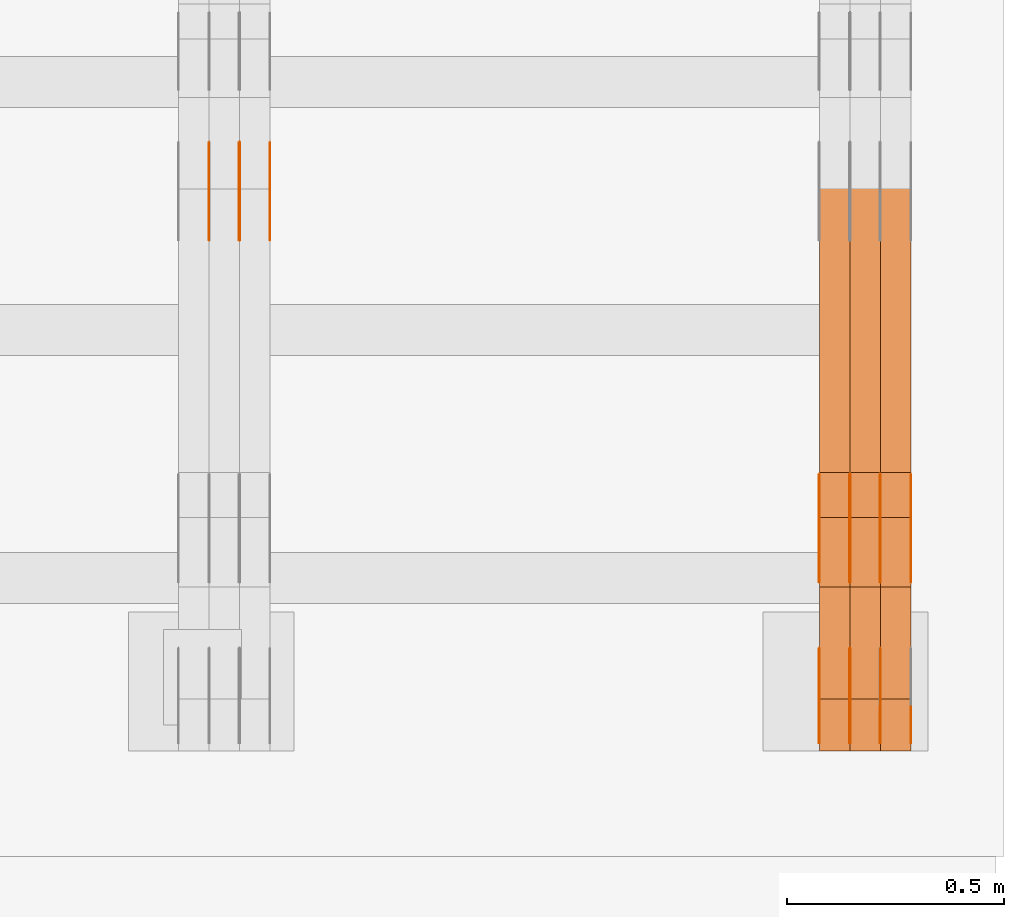
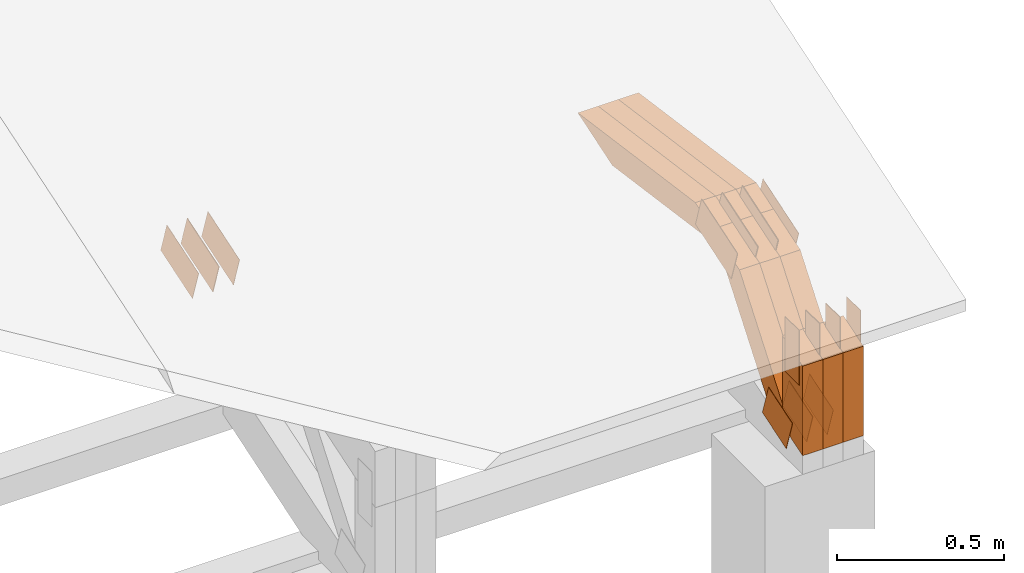
# One storey, part 307 of 385: 29 proxies.
"""IFC2X3 building model written with IfcOpenShell, lengths in millimetres."""

import ifcopenshell
import ifcopenshell.guid

model = None  # the IFC model being written
_history = None  # IfcOwnerHistory: only IFC2X3 demands one
_inside = {}  # id of a spatial element -> (the spatial element, [elements in it])
_under = {}  # id of a project, library or spatial element -> (it, [spatial elements below it])
_declared = {}  # id of a project -> (the project, [libraries it declares])
_typed = {}  # id of a type object -> (the type object, [elements of that type])
_made_of = {}  # id of a material, layer set ... -> (it, [elements and type objects made of it])


def new_model(schema):
    """Start an empty IFC model of exactly this schema.

    Asked for "IFC4X3", IfcOpenShell would pick the latest addendum, in which some entities
    have other attributes; the version numbers below select the first issue.
    IFC2X3 requires an IfcOwnerHistory on every rooted entity: one is made here for all.
    """
    global model, _history
    if schema == "IFC4X3":
        model = ifcopenshell.file(schema_version=(4, 3, 0, 0))
    else:
        model = ifcopenshell.file(schema=schema)
    _inside.clear()
    _under.clear()
    _declared.clear()
    _typed.clear()
    _made_of.clear()
    _history = None
    if model.schema == "IFC2X3":
        org = make("IfcOrganization", Name="unknown")
        user = make(
            "IfcPersonAndOrganization",
            ThePerson=make("IfcPerson", FamilyName="unknown"),
            TheOrganization=org,
        )
        app = make(
            "IfcApplication",
            ApplicationDeveloper=org,
            Version="unknown",
            ApplicationFullName="unknown",
            ApplicationIdentifier="unknown",
        )
        _history = make(
            "IfcOwnerHistory",
            OwningUser=user,
            OwningApplication=app,
            ChangeAction="ADDED",
            CreationDate=0,
        )
    return model


def make(cls, **values):
    """One entity of the class cls with the attributes given. An attribute that is None is left unset."""
    return model.create_entity(
        cls, **{name: value for name, value in values.items() if value is not None}
    )


def entity(cls, *values):
    """Any entity or typed value of the class cls, its attributes in the order of the schema. None: left unset."""
    e = model.create_entity(cls)
    for i, value in enumerate(values):
        if value is not None:
            e[i] = value
    return e


def rooted(cls, **values):
    """An entity with a GlobalId (a new one), such as an element, a storey or a relation."""
    return make(cls, GlobalId=ifcopenshell.guid.new(), OwnerHistory=_history, **values)


def si_unit(unit_type, name, prefix=None):
    """IfcSIUnit, for example si_unit("LENGTHUNIT", "METRE", prefix="MILLI")."""
    return make("IfcSIUnit", UnitType=unit_type, Prefix=prefix, Name=name)


def converted_unit(unit_type, name, factor, base, dimensions=None, offset=None):
    """IfcConversionBasedUnit, such as the inch: factor (a typed value) times the base unit."""
    return make(
        "IfcConversionBasedUnit"
        if offset is None
        else "IfcConversionBasedUnitWithOffset",
        ConversionOffset=offset,
        Dimensions=None
        if dimensions is None
        else entity("IfcDimensionalExponents", *dimensions),
        UnitType=unit_type,
        Name=name,
        ConversionFactor=make(
            "IfcMeasureWithUnit", ValueComponent=factor, UnitComponent=base
        ),
    )


def derived_unit(unit_type, elements):
    """IfcDerivedUnit: a product of units, each with its exponent."""
    return make(
        "IfcDerivedUnit",
        Elements=[
            make("IfcDerivedUnitElement", Unit=unit, Exponent=power)
            for unit, power in elements
        ],
        UnitType=unit_type,
    )


def assignment(units):
    """IfcUnitAssignment: the units of a project."""
    return None if units is None else make("IfcUnitAssignment", Units=units)


def point(xyz):
    """IfcCartesianPoint."""
    return None if xyz is None else make("IfcCartesianPoint", Coordinates=xyz)


def direction(xyz):
    """IfcDirection."""
    return None if xyz is None else make("IfcDirection", DirectionRatios=xyz)


def frame(location, z_axis=None, x_axis=None):
    """IfcAxis2Placement3D, a coordinate frame: its origin and axes. An axis left out is left unset."""
    return make(
        "IfcAxis2Placement3D",
        Location=point(location),
        Axis=direction(z_axis),
        RefDirection=direction(x_axis),
    )


def frame_2d(location, x_axis=None):
    """IfcAxis2Placement2D, a coordinate frame in the plane: its origin and x axis."""
    return make(
        "IfcAxis2Placement2D", Location=point(location), RefDirection=direction(x_axis)
    )


def origin():
    """The frame at (0, 0, 0) with its axes left unset."""
    return frame((0.0, 0.0, 0.0))


def place(relative_to, where):
    """IfcLocalPlacement: puts the frame where relative to a parent placement (None: the world)."""
    return make(
        "IfcLocalPlacement", PlacementRelTo=relative_to, RelativePlacement=where
    )


def context(
    kind, dimensions, precision=None, world=None, true_north=None, identifier=None
):
    """IfcGeometricRepresentationContext, for example the 3D "Model" context."""
    return make(
        "IfcGeometricRepresentationContext",
        ContextIdentifier=identifier,
        ContextType=kind,
        CoordinateSpaceDimension=dimensions,
        Precision=precision,
        WorldCoordinateSystem=world,
        TrueNorth=true_north,
    )


def subcontext(parent, identifier, kind, view, scale=None):
    """IfcGeometricRepresentationSubContext, for example "Body" below "Model"."""
    return make(
        "IfcGeometricRepresentationSubContext",
        ContextIdentifier=identifier,
        ContextType=kind,
        ParentContext=parent,
        TargetScale=scale,
        TargetView=view,
    )


def project(units=None, contexts=None):
    """IfcProject with its units and contexts."""
    return rooted(
        "IfcProject",
        Name="project",
        RepresentationContexts=contexts,
        UnitsInContext=assignment(units),
    )


def spatial(cls, under=None, at=None, **own):
    """A site, building, storey or space (cls), placed at a placement, below another one or the project."""
    s = rooted(cls, ObjectPlacement=at, **own)
    if under is not None:
        _under.setdefault(under.id(), (under, []))[1].append(s)
    return s


def polyline(points):
    """IfcPolyline through the points."""
    return make("IfcPolyline", Points=[point(p) for p in points])


def profile(cls, at=None, kind="AREA", **sizes):
    """A parametric profile (cls). Its sizes go by their IFC names, for example OverallWidth=200.0."""
    return make(cls, ProfileType=kind, Position=at, **sizes)


def rectangle(**sizes):
    """IfcRectangleProfileDef."""
    return profile("IfcRectangleProfileDef", **sizes)


def outline(outer, holes=None, kind="AREA"):
    """IfcArbitraryClosedProfileDef: a profile drawn as a closed curve; with holes, ...WithVoids."""
    if holes is None:
        return make("IfcArbitraryClosedProfileDef", ProfileType=kind, OuterCurve=outer)
    return make(
        "IfcArbitraryProfileDefWithVoids",
        ProfileType=kind,
        OuterCurve=outer,
        InnerCurves=holes,
    )


def extrude(swept, where, along, depth):
    """IfcExtrudedAreaSolid: the profile swept, set in the frame where, extruded along a direction by depth."""
    return make(
        "IfcExtrudedAreaSolid",
        SweptArea=swept,
        Position=where,
        ExtrudedDirection=direction(along),
        Depth=depth,
    )


def shape(context_of_items, identifier, shape_type, items):
    """IfcShapeRepresentation: the items that make up one representation, for example the "Body"."""
    return make(
        "IfcShapeRepresentation",
        ContextOfItems=context_of_items,
        RepresentationIdentifier=identifier,
        RepresentationType=shape_type,
        Items=items,
    )


def source(mapping_origin, context_of_items, identifier, shape_type, items):
    """IfcRepresentationMap: a shape defined once, which mapped items show again and again."""
    return make(
        "IfcRepresentationMap",
        MappingOrigin=mapping_origin,
        MappedRepresentation=shape(context_of_items, identifier, shape_type, items),
    )


def transform(
    local_origin,
    x_axis=None,
    y_axis=None,
    z_axis=None,
    scale=None,
    scale2=None,
    scale3=None,
    uniform=True,
):
    """IfcCartesianTransformationOperator3D, or its non-uniform kind. x_axis, y_axis, z_axis: its Axis1, 2, 3."""
    if uniform:
        return make(
            "IfcCartesianTransformationOperator3D",
            Axis1=direction(x_axis),
            Axis2=direction(y_axis),
            LocalOrigin=point(local_origin),
            Scale=scale,
            Axis3=direction(z_axis),
        )
    return make(
        "IfcCartesianTransformationOperator3DnonUniform",
        Axis1=direction(x_axis),
        Axis2=direction(y_axis),
        LocalOrigin=point(local_origin),
        Scale=scale,
        Axis3=direction(z_axis),
        Scale2=scale2,
        Scale3=scale3,
    )


def mapped(mapping_source, mapping_target):
    """IfcMappedItem: shows the shape of a source again, moved by a transform."""
    return make(
        "IfcMappedItem", MappingSource=mapping_source, MappingTarget=mapping_target
    )


def material(Name=None, Category=None):
    """IfcMaterial."""
    return make("IfcMaterial", Name=Name, Category=Category)


def made_of(thing, what):
    """Note that an element or type object is made of a material, layer set ...; save() writes the relation."""
    if what is not None:
        _made_of.setdefault(what.id(), (what, []))[1].append(thing)
    return thing


def type_object(cls, material=None, **own):
    """A type object (cls), such as IfcWallType, which elements share."""
    return made_of(rooted(cls, **own), material)


def type_shapes(of_type, sources):
    """Give a type object the sources (RepresentationMaps) that its elements show as mapped items."""
    of_type.RepresentationMaps = sources


def element(
    cls,
    number,
    at=None,
    inside=None,
    cuts=None,
    type_object=None,
    material=None,
    context=None,
    identifier="Body",
    shape_type=None,
    held_by="IfcProductDefinitionShape",
    body=None,
    shapes=None,
    **own,
):
    """One element of the class cls, such as IfcWall. Its Tag is "e" and its number.

    at: its placement. inside: the storey or other place that contains it. cuts: it is an
    opening in that element (IfcRelVoidsElement). A single representation is given by context,
    identifier, shape_type and body (its items); several are given by shapes. held_by: the class
    of the entity that holds the representations. save() writes the other relations.
    """
    e = rooted(cls, Tag="e%d" % number, ObjectPlacement=at, **own)
    if body is not None:
        shapes = [shape(context, identifier, shape_type, body)]
    if shapes is not None:
        e.Representation = make(held_by, Representations=shapes)
    if inside is not None:
        _inside.setdefault(inside.id(), (inside, []))[1].append(e)
    if cuts is not None:
        rooted(
            "IfcRelVoidsElement", RelatingBuildingElement=cuts, RelatedOpeningElement=e
        )
    if type_object is not None:
        _typed.setdefault(type_object.id(), (type_object, []))[1].append(e)
    return made_of(e, material)


def aggregate(whole, parts):
    """IfcRelAggregates: a whole, such as a stair, and the parts it consists of."""
    return rooted("IfcRelAggregates", RelatingObject=whole, RelatedObjects=parts)


def save(model, path):
    """Write the relations noted so far, then the file.

    IfcRelAggregates (storeys below a building ...), IfcRelContainedInSpatialStructure (elements
    in a storey), IfcRelDefinesByType, IfcRelAssociatesMaterial and IfcRelDeclares: one each for
    every whole, place, type object, material and project.
    """
    for whole, parts in _under.values():
        aggregate(whole, parts)
    for where, things in _inside.values():
        rooted(
            "IfcRelContainedInSpatialStructure",
            RelatedElements=things,
            RelatingStructure=where,
        )
    for kind, things in _typed.values():
        rooted("IfcRelDefinesByType", RelatedObjects=things, RelatingType=kind)
    for what, things in _made_of.values():
        rooted("IfcRelAssociatesMaterial", RelatedObjects=things, RelatingMaterial=what)
    for by, libraries in _declared.values():
        rooted("IfcRelDeclares", RelatingContext=by, RelatedDefinitions=libraries)
    model.write(path)


model = new_model("IFC2X3")

# Units and contexts
model_context = context("Model", 3, precision=0.01, world=origin(), true_north=direction((6.12303176911189e-17, 1.0)))
body_context = subcontext(model_context, "Body", "Model", "MODEL_VIEW")
ifc_project = project(units=[si_unit("LENGTHUNIT", "METRE", prefix="MILLI"), si_unit("AREAUNIT", "SQUARE_METRE"), si_unit("VOLUMEUNIT", "CUBIC_METRE"), converted_unit("PLANEANGLEUNIT", "DEGREE", entity("IfcRatioMeasure", 0.0174532925199433), si_unit("PLANEANGLEUNIT", "RADIAN"), dimensions=[0, 0, 0, 0, 0, 0, 0]), si_unit("MASSUNIT", "GRAM", prefix="KILO"), derived_unit("MASSDENSITYUNIT", [(si_unit("MASSUNIT", "GRAM", prefix="KILO"), 1), (si_unit("LENGTHUNIT", "METRE"), -3)]), si_unit("TIMEUNIT", "SECOND"), si_unit("FREQUENCYUNIT", "HERTZ"), si_unit("THERMODYNAMICTEMPERATUREUNIT", "DEGREE_CELSIUS"), derived_unit("THERMALTRANSMITTANCEUNIT", [(si_unit("MASSUNIT", "GRAM", prefix="KILO"), 1), (si_unit("THERMODYNAMICTEMPERATUREUNIT", "KELVIN"), -1), (si_unit("TIMEUNIT", "SECOND"), -3)]), derived_unit("VOLUMETRICFLOWRATEUNIT", [(si_unit("LENGTHUNIT", "METRE"), 3), (si_unit("TIMEUNIT", "SECOND"), -1)]), si_unit("ELECTRICCURRENTUNIT", "AMPERE"), si_unit("ELECTRICVOLTAGEUNIT", "VOLT"), si_unit("POWERUNIT", "WATT"), si_unit("FORCEUNIT", "NEWTON", prefix="KILO"), si_unit("ILLUMINANCEUNIT", "LUX"), si_unit("LUMINOUSFLUXUNIT", "LUMEN"), si_unit("LUMINOUSINTENSITYUNIT", "CANDELA"), derived_unit("USERDEFINED", [(si_unit("MASSUNIT", "GRAM", prefix="KILO"), -1), (si_unit("LENGTHUNIT", "METRE"), -2), (si_unit("TIMEUNIT", "SECOND"), 3), (si_unit("LUMINOUSFLUXUNIT", "LUMEN"), 1)]), derived_unit("LINEARVELOCITYUNIT", [(si_unit("LENGTHUNIT", "METRE"), 1), (si_unit("TIMEUNIT", "SECOND"), -1)]), si_unit("PRESSUREUNIT", "PASCAL"), derived_unit("USERDEFINED", [(si_unit("LENGTHUNIT", "METRE"), -2), (si_unit("MASSUNIT", "GRAM", prefix="KILO"), 1), (si_unit("TIMEUNIT", "SECOND"), -2)])], contexts=[model_context])

# Site, building, storey
site_placement = place(None, origin())
site = spatial("IfcSite", under=ifc_project, at=site_placement, CompositionType="ELEMENT")
building_placement = place(site_placement, origin())
building = spatial("IfcBuilding", under=site, at=building_placement, CompositionType="ELEMENT")
storey_placement = place(building_placement, origin())
storey = spatial("IfcBuildingStorey", under=building, at=storey_placement, Name="Default", CompositionType="ELEMENT", Elevation=0.0)

# Proxies
ifc_material_1 = material(Name="IfcSurfaceStyle #615370")
building_element_proxy_type_1 = type_object("IfcBuildingElementProxyType", PredefinedType="NOTDEFINED", material=ifc_material_1)
shared_shape_1 = source(origin(), body_context, "Body", "SweptSolid", [
    extrude(outline(polyline([(-74.999865408764, -60.0000379172698), (74.9998729365771, -60.0000379172698), (74.9998642299588, 60.0000379172698), (-74.9998717577719, 60.0000379172698), (-74.999865408764, -60.0000379172698)])), frame((75.0005044383734, 60.0001679035349, 0.0), z_axis=(0.0, 0.0, 1.0), x_axis=(-1.0, 0.0, 0.0)), (0.0, 0.0, 1.0), 1.3),
])
type_shapes(building_element_proxy_type_1, [shared_shape_1])
proxy_1_placement = place(building_placement, frame((49791.3, 2998.66143710397, 150.423871180894), z_axis=(-1.0, 0.0, 0.0), x_axis=(0.0, 0.951056516295124, 0.309016994375039)))
element("IfcBuildingElementProxy", 1, at=proxy_1_placement, inside=storey, type_object=building_element_proxy_type_1, material=ifc_material_1, context=body_context, shape_type="MappedRepresentation", body=[
    mapped(shared_shape_1, transform((0.0, 0.0, 0.0), scale=1.0)),
])
ifc_material_2 = material(Name="IfcSurfaceStyle #615313")
building_element_proxy_type_2 = type_object("IfcBuildingElementProxyType", PredefinedType="NOTDEFINED", material=ifc_material_2)
shared_shape_2 = source(origin(), body_context, "Body", "SweptSolid", [
    extrude(outline(polyline([(-74.999865408764, -60.0000379172698), (74.9998729365771, -60.0000379172698), (74.9998642299588, 60.0000379172698), (-74.9998717577719, 60.0000379172698), (-74.999865408764, -60.0000379172698)])), frame((75.0005044383734, 60.0001679035349, 0.0), z_axis=(0.0, 0.0, 1.0), x_axis=(-1.0, 0.0, 0.0)), (0.0, 0.0, 1.0), 1.29999999999999),
])
type_shapes(building_element_proxy_type_2, [shared_shape_2])
proxy_2_placement = place(building_placement, frame((49720.0, 2998.66143710397, 150.423871180894), z_axis=(-1.0, 0.0, 0.0), x_axis=(0.0, 0.951056516295124, 0.309016994375039)))
element("IfcBuildingElementProxy", 2, at=proxy_2_placement, inside=storey, type_object=building_element_proxy_type_2, material=ifc_material_2, context=body_context, shape_type="MappedRepresentation", body=[
    mapped(shared_shape_2, transform((0.0, 0.0, 0.0), scale=1.0)),
])
ifc_material_3 = material(Name="IfcSurfaceStyle #615256")
building_element_proxy_type_3 = type_object("IfcBuildingElementProxyType", PredefinedType="NOTDEFINED", material=ifc_material_3)
shared_shape_3 = source(origin(), body_context, "Body", "SweptSolid", [
    extrude(outline(polyline([(-74.999865408764, -60.0000379172698), (74.9998729365771, -60.0000379172698), (74.9998642299588, 60.0000379172698), (-74.9998717577719, 60.0000379172698), (-74.999865408764, -60.0000379172698)])), frame((75.0005044383734, 60.0001679035349, 0.0), z_axis=(0.0, 0.0, 1.0), x_axis=(-1.0, 0.0, 0.0)), (0.0, 0.0, 1.0), 1.29999999999999),
])
type_shapes(building_element_proxy_type_3, [shared_shape_3])
proxy_3_placement = place(building_placement, frame((49721.3, 2998.66143710397, 150.423871180894), z_axis=(-1.0, 0.0, 0.0), x_axis=(0.0, 0.951056516295124, 0.309016994375039)))
element("IfcBuildingElementProxy", 3, at=proxy_3_placement, inside=storey, type_object=building_element_proxy_type_3, material=ifc_material_3, context=body_context, shape_type="MappedRepresentation", body=[
    mapped(shared_shape_3, transform((0.0, 0.0, 0.0), scale=1.0)),
])
ifc_material_4 = material(Name="IfcSurfaceStyle #615199")
building_element_proxy_type_4 = type_object("IfcBuildingElementProxyType", PredefinedType="NOTDEFINED", material=ifc_material_4)
shared_shape_4 = source(origin(), body_context, "Body", "SweptSolid", [
    extrude(outline(polyline([(-74.999865408764, -60.0000379172698), (74.9998729365771, -60.0000379172698), (74.9998642299588, 60.0000379172698), (-74.9998717577719, 60.0000379172698), (-74.999865408764, -60.0000379172698)])), frame((75.0005044383734, 60.0001679035349, 0.0), z_axis=(0.0, 0.0, 1.0), x_axis=(-1.0, 0.0, 0.0)), (0.0, 0.0, 1.0), 1.29999999999999),
])
type_shapes(building_element_proxy_type_4, [shared_shape_4])
proxy_4_placement = place(building_placement, frame((49650.0, 2998.66143710397, 150.423871180894), z_axis=(-1.0, 0.0, 0.0), x_axis=(0.0, 0.951056516295124, 0.309016994375039)))
element("IfcBuildingElementProxy", 4, at=proxy_4_placement, inside=storey, type_object=building_element_proxy_type_4, material=ifc_material_4, context=body_context, shape_type="MappedRepresentation", body=[
    mapped(shared_shape_4, transform((0.0, 0.0, 0.0), scale=1.0)),
])
ifc_material_5 = material(Name="IfcSurfaceStyle #606934")
building_element_proxy_type_5 = type_object("IfcBuildingElementProxyType", PredefinedType="NOTDEFINED", material=ifc_material_5)
shared_shape_5 = source(origin(), body_context, "Body", "SweptSolid", [
    extrude(outline(polyline([(-112.500266735783, -59.9999130784581), (112.500275442392, -59.9999130784581), (112.500262020557, 59.9999130784582), (-112.500270727166, 59.9999130784581), (-112.500266735783, -59.9999130784581)])), frame((112.500275442392, 60.0001020984692, 0.0), z_axis=(0.0, 0.0, 1.0), x_axis=(-1.0, 0.0, 0.0)), (0.0, 0.0, 1.0), 1.3),
])
type_shapes(building_element_proxy_type_5, [shared_shape_5])
proxy_5_placement = place(building_placement, frame((49861.3, 3327.32420598508, 571.284602786019), z_axis=(-1.0, 0.0, 0.0), x_axis=(0.0, 0.951056516295154, 0.309016994374948)))
element("IfcBuildingElementProxy", 5, at=proxy_5_placement, inside=storey, type_object=building_element_proxy_type_5, material=ifc_material_5, context=body_context, shape_type="MappedRepresentation", body=[
    mapped(shared_shape_5, transform((0.0, 0.0, 0.0), scale=1.0)),
])
ifc_material_6 = material(Name="IfcSurfaceStyle #606877")
building_element_proxy_type_6 = type_object("IfcBuildingElementProxyType", PredefinedType="NOTDEFINED", material=ifc_material_6)
shared_shape_6 = source(origin(), body_context, "Body", "SweptSolid", [
    extrude(outline(polyline([(-112.500266735783, -59.9999130784581), (112.500275442392, -59.9999130784581), (112.500262020557, 59.9999130784582), (-112.500270727166, 59.9999130784581), (-112.500266735783, -59.9999130784581)])), frame((112.500275442392, 60.0001020984692, 0.0), z_axis=(0.0, 0.0, 1.0), x_axis=(-1.0, 0.0, 0.0)), (0.0, 0.0, 1.0), 1.3),
])
type_shapes(building_element_proxy_type_6, [shared_shape_6])
proxy_6_placement = place(building_placement, frame((49790.0, 3327.32420598508, 571.284602786019), z_axis=(-1.0, 0.0, 0.0), x_axis=(0.0, 0.951056516295154, 0.309016994374948)))
element("IfcBuildingElementProxy", 6, at=proxy_6_placement, inside=storey, type_object=building_element_proxy_type_6, material=ifc_material_6, context=body_context, shape_type="MappedRepresentation", body=[
    mapped(shared_shape_6, transform((0.0, 0.0, 0.0), scale=1.0)),
])
ifc_material_7 = material(Name="IfcSurfaceStyle #606820")
building_element_proxy_type_7 = type_object("IfcBuildingElementProxyType", PredefinedType="NOTDEFINED", material=ifc_material_7)
shared_shape_7 = source(origin(), body_context, "Body", "SweptSolid", [
    extrude(outline(polyline([(-112.500266735783, -59.9999130784581), (112.500275442392, -59.9999130784581), (112.500262020557, 59.9999130784582), (-112.500270727166, 59.9999130784581), (-112.500266735783, -59.9999130784581)])), frame((112.500275442392, 60.0001020984692, 0.0), z_axis=(0.0, 0.0, 1.0), x_axis=(-1.0, 0.0, 0.0)), (0.0, 0.0, 1.0), 1.3),
])
type_shapes(building_element_proxy_type_7, [shared_shape_7])
proxy_7_placement = place(building_placement, frame((49791.3, 3327.32420598508, 571.284602786019), z_axis=(-1.0, 0.0, 0.0), x_axis=(0.0, 0.951056516295154, 0.309016994374948)))
element("IfcBuildingElementProxy", 7, at=proxy_7_placement, inside=storey, type_object=building_element_proxy_type_7, material=ifc_material_7, context=body_context, shape_type="MappedRepresentation", body=[
    mapped(shared_shape_7, transform((0.0, 0.0, 0.0), scale=1.0)),
])
ifc_material_8 = material(Name="IfcSurfaceStyle #606763")
building_element_proxy_type_8 = type_object("IfcBuildingElementProxyType", PredefinedType="NOTDEFINED", material=ifc_material_8)
shared_shape_8 = source(origin(), body_context, "Body", "SweptSolid", [
    extrude(outline(polyline([(-112.500266735783, -59.9999130784581), (112.500275442392, -59.9999130784581), (112.500262020557, 59.9999130784582), (-112.500270727166, 59.9999130784581), (-112.500266735783, -59.9999130784581)])), frame((112.500275442392, 60.0001020984692, 0.0), z_axis=(0.0, 0.0, 1.0), x_axis=(-1.0, 0.0, 0.0)), (0.0, 0.0, 1.0), 1.29999999999998),
])
type_shapes(building_element_proxy_type_8, [shared_shape_8])
proxy_8_placement = place(building_placement, frame((49720.0, 3327.32420598508, 571.284602786019), z_axis=(-1.0, 0.0, 0.0), x_axis=(0.0, 0.951056516295154, 0.309016994374948)))
element("IfcBuildingElementProxy", 8, at=proxy_8_placement, inside=storey, type_object=building_element_proxy_type_8, material=ifc_material_8, context=body_context, shape_type="MappedRepresentation", body=[
    mapped(shared_shape_8, transform((0.0, 0.0, 0.0), scale=1.0)),
])
ifc_material_9 = material(Name="IfcSurfaceStyle #606706")
building_element_proxy_type_9 = type_object("IfcBuildingElementProxyType", PredefinedType="NOTDEFINED", material=ifc_material_9)
shared_shape_9 = source(origin(), body_context, "Body", "SweptSolid", [
    extrude(outline(polyline([(-112.500266735783, -59.9999130784581), (112.500275442392, -59.9999130784581), (112.500262020557, 59.9999130784582), (-112.500270727166, 59.9999130784581), (-112.500266735783, -59.9999130784581)])), frame((112.500275442392, 60.0001020984692, 0.0), z_axis=(0.0, 0.0, 1.0), x_axis=(-1.0, 0.0, 0.0)), (0.0, 0.0, 1.0), 1.29999999999998),
])
type_shapes(building_element_proxy_type_9, [shared_shape_9])
proxy_9_placement = place(building_placement, frame((49721.3, 3327.32420598508, 571.284602786019), z_axis=(-1.0, 0.0, 0.0), x_axis=(0.0, 0.951056516295154, 0.309016994374948)))
element("IfcBuildingElementProxy", 9, at=proxy_9_placement, inside=storey, type_object=building_element_proxy_type_9, material=ifc_material_9, context=body_context, shape_type="MappedRepresentation", body=[
    mapped(shared_shape_9, transform((0.0, 0.0, 0.0), scale=1.0)),
])
ifc_material_10 = material(Name="IfcSurfaceStyle #606649")
building_element_proxy_type_10 = type_object("IfcBuildingElementProxyType", PredefinedType="NOTDEFINED", material=ifc_material_10)
shared_shape_10 = source(origin(), body_context, "Body", "SweptSolid", [
    extrude(outline(polyline([(-112.500266735783, -59.9999130784581), (112.500275442392, -59.9999130784581), (112.500262020557, 59.9999130784582), (-112.500270727166, 59.9999130784581), (-112.500266735783, -59.9999130784581)])), frame((112.500275442392, 60.0001020984692, 0.0), z_axis=(0.0, 0.0, 1.0), x_axis=(-1.0, 0.0, 0.0)), (0.0, 0.0, 1.0), 1.29999999999999),
])
type_shapes(building_element_proxy_type_10, [shared_shape_10])
proxy_10_placement = place(building_placement, frame((49650.0, 3327.32420598508, 571.284602786019), z_axis=(-1.0, 0.0, 0.0), x_axis=(0.0, 0.951056516295154, 0.309016994374948)))
element("IfcBuildingElementProxy", 10, at=proxy_10_placement, inside=storey, type_object=building_element_proxy_type_10, material=ifc_material_10, context=body_context, shape_type="MappedRepresentation", body=[
    mapped(shared_shape_10, transform((0.0, 0.0, 0.0), scale=1.0)),
])
ifc_material_11 = material(Name="IfcSurfaceStyle #605908")
building_element_proxy_type_11 = type_object("IfcBuildingElementProxyType", PredefinedType="NOTDEFINED", material=ifc_material_11)
shared_shape_11 = source(origin(), body_context, "Body", "SweptSolid", [
    extrude(rectangle(XDim=199.999969482422, YDim=84.0, at=frame_2d((1.4210854715202e-14, 0.0), x_axis=(1.0, 0.0))), frame((100.000010815955, 42.0, 0.0), z_axis=(0.0, 0.0, 1.0), x_axis=(-1.0, 0.0, 0.0)), (0.0, 0.0, 1.0), 1.3),
])
type_shapes(building_element_proxy_type_11, [shared_shape_11])
proxy_11_placement = place(building_placement, frame((49861.3, 3042.0, 514.460048047401), z_axis=(-1.0, 0.0, 0.0), x_axis=(0.0, 0.0, -1.0)))
element("IfcBuildingElementProxy", 11, at=proxy_11_placement, inside=storey, type_object=building_element_proxy_type_11, material=ifc_material_11, context=body_context, shape_type="MappedRepresentation", body=[
    mapped(shared_shape_11, transform((0.0, 0.0, 0.0), scale=1.0)),
])
ifc_material_12 = material(Name="IfcSurfaceStyle #605851")
building_element_proxy_type_12 = type_object("IfcBuildingElementProxyType", PredefinedType="NOTDEFINED", material=ifc_material_12)
shared_shape_12 = source(origin(), body_context, "Body", "SweptSolid", [
    extrude(rectangle(XDim=199.999969482422, YDim=84.0, at=frame_2d((1.4210854715202e-14, 0.0), x_axis=(1.0, 0.0))), frame((100.000010815955, 42.0, 0.0), z_axis=(0.0, 0.0, 1.0), x_axis=(-1.0, 0.0, 0.0)), (0.0, 0.0, 1.0), 1.3),
])
type_shapes(building_element_proxy_type_12, [shared_shape_12])
proxy_12_placement = place(building_placement, frame((49790.0, 3042.0, 514.460048047401), z_axis=(-1.0, 0.0, 0.0), x_axis=(0.0, 0.0, -1.0)))
element("IfcBuildingElementProxy", 12, at=proxy_12_placement, inside=storey, type_object=building_element_proxy_type_12, material=ifc_material_12, context=body_context, shape_type="MappedRepresentation", body=[
    mapped(shared_shape_12, transform((0.0, 0.0, 0.0), scale=1.0)),
])
ifc_material_13 = material(Name="IfcSurfaceStyle #605794")
building_element_proxy_type_13 = type_object("IfcBuildingElementProxyType", PredefinedType="NOTDEFINED", material=ifc_material_13)
shared_shape_13 = source(origin(), body_context, "Body", "SweptSolid", [
    extrude(rectangle(XDim=199.999969482422, YDim=84.0, at=frame_2d((1.4210854715202e-14, 0.0), x_axis=(1.0, 0.0))), frame((100.000010815955, 42.0, 0.0), z_axis=(0.0, 0.0, 1.0), x_axis=(-1.0, 0.0, 0.0)), (0.0, 0.0, 1.0), 1.3),
])
type_shapes(building_element_proxy_type_13, [shared_shape_13])
proxy_13_placement = place(building_placement, frame((49791.3, 3042.0, 514.460048047401), z_axis=(-1.0, 0.0, 0.0), x_axis=(0.0, 0.0, -1.0)))
element("IfcBuildingElementProxy", 13, at=proxy_13_placement, inside=storey, type_object=building_element_proxy_type_13, material=ifc_material_13, context=body_context, shape_type="MappedRepresentation", body=[
    mapped(shared_shape_13, transform((0.0, 0.0, 0.0), scale=1.0)),
])
ifc_material_14 = material(Name="IfcSurfaceStyle #605737")
building_element_proxy_type_14 = type_object("IfcBuildingElementProxyType", PredefinedType="NOTDEFINED", material=ifc_material_14)
shared_shape_14 = source(origin(), body_context, "Body", "SweptSolid", [
    extrude(rectangle(XDim=199.999969482422, YDim=84.0, at=frame_2d((1.4210854715202e-14, 0.0), x_axis=(1.0, 0.0))), frame((100.000010815955, 42.0, 0.0), z_axis=(0.0, 0.0, 1.0), x_axis=(-1.0, 0.0, 0.0)), (0.0, 0.0, 1.0), 1.29999999999998),
])
type_shapes(building_element_proxy_type_14, [shared_shape_14])
proxy_14_placement = place(building_placement, frame((49720.0, 3042.0, 514.460048047401), z_axis=(-1.0, 0.0, 0.0), x_axis=(0.0, 0.0, -1.0)))
element("IfcBuildingElementProxy", 14, at=proxy_14_placement, inside=storey, type_object=building_element_proxy_type_14, material=ifc_material_14, context=body_context, shape_type="MappedRepresentation", body=[
    mapped(shared_shape_14, transform((0.0, 0.0, 0.0), scale=1.0)),
])
ifc_material_15 = material(Name="IfcSurfaceStyle #605680")
building_element_proxy_type_15 = type_object("IfcBuildingElementProxyType", PredefinedType="NOTDEFINED", material=ifc_material_15)
shared_shape_15 = source(origin(), body_context, "Body", "SweptSolid", [
    extrude(rectangle(XDim=199.999969482422, YDim=84.0, at=frame_2d((1.4210854715202e-14, 0.0), x_axis=(1.0, 0.0))), frame((100.000010815955, 42.0, 0.0), z_axis=(0.0, 0.0, 1.0), x_axis=(-1.0, 0.0, 0.0)), (0.0, 0.0, 1.0), 1.29999999999998),
])
type_shapes(building_element_proxy_type_15, [shared_shape_15])
proxy_15_placement = place(building_placement, frame((49721.3, 3042.0, 514.460048047401), z_axis=(-1.0, 0.0, 0.0), x_axis=(0.0, 0.0, -1.0)))
element("IfcBuildingElementProxy", 15, at=proxy_15_placement, inside=storey, type_object=building_element_proxy_type_15, material=ifc_material_15, context=body_context, shape_type="MappedRepresentation", body=[
    mapped(shared_shape_15, transform((0.0, 0.0, 0.0), scale=1.0)),
])
ifc_material_16 = material(Name="IfcSurfaceStyle #605623")
building_element_proxy_type_16 = type_object("IfcBuildingElementProxyType", PredefinedType="NOTDEFINED", material=ifc_material_16)
shared_shape_16 = source(origin(), body_context, "Body", "SweptSolid", [
    extrude(rectangle(XDim=199.999969482422, YDim=84.0, at=frame_2d((1.4210854715202e-14, 0.0), x_axis=(1.0, 0.0))), frame((100.000010815955, 42.0, 0.0), z_axis=(0.0, 0.0, 1.0), x_axis=(-1.0, 0.0, 0.0)), (0.0, 0.0, 1.0), 1.29999999999999),
])
type_shapes(building_element_proxy_type_16, [shared_shape_16])
proxy_16_placement = place(building_placement, frame((49650.0, 3042.0, 514.460048047401), z_axis=(-1.0, 0.0, 0.0), x_axis=(0.0, 0.0, -1.0)))
element("IfcBuildingElementProxy", 16, at=proxy_16_placement, inside=storey, type_object=building_element_proxy_type_16, material=ifc_material_16, context=body_context, shape_type="MappedRepresentation", body=[
    mapped(shared_shape_16, transform((0.0, 0.0, 0.0), scale=1.0)),
])
ifc_material_17 = material(Name="IfcSurfaceStyle #594640")
building_element_proxy_type_17 = type_object("IfcBuildingElementProxyType", Name="T2-W3 594638", PredefinedType="NOTDEFINED", material=ifc_material_17)
shared_shape_17 = source(origin(), body_context, "Body", "SweptSolid", [
    extrude(outline(polyline([(-314.232579911788, -47.5000200125938), (325.164873061766, -47.5000200125938), (297.999869081008, 6.48085173424295e-05), (200.434027234171, 47.4999876083351), (-509.366189465157, 47.4999876083352), (-314.232579911788, -47.5000200125938)])), frame((325.164873061766, 47.5001564752191, 0.0), z_axis=(0.0, 0.0, 1.0), x_axis=(-1.0, 0.0, 0.0)), (0.0, 0.0, 1.0), 70.0),
])
type_shapes(building_element_proxy_type_17, [shared_shape_17])
proxy_17_placement = place(building_placement, frame((49860.0, 3457.43747924875, 620.49890325051), z_axis=(-1.0, 0.0, 0.0), x_axis=(0.0, 0.990367219823621, -0.138465771578512)))
element("IfcBuildingElementProxy", 17, at=proxy_17_placement, inside=storey, type_object=building_element_proxy_type_17, material=ifc_material_17, Name="T2-W3", context=body_context, shape_type="MappedRepresentation", body=[
    mapped(shared_shape_17, transform((0.0, 0.0, 0.0), scale=1.0)),
])
ifc_material_18 = material(Name="IfcSurfaceStyle #594574")
building_element_proxy_type_18 = type_object("IfcBuildingElementProxyType", Name="T2-W3 594572", PredefinedType="NOTDEFINED", material=ifc_material_18)
shared_shape_18 = source(origin(), body_context, "Body", "SweptSolid", [
    extrude(outline(polyline([(-314.232579911788, -47.5000200125938), (325.164873061766, -47.5000200125938), (297.999869081008, 6.48085173424295e-05), (200.434027234171, 47.4999876083351), (-509.366189465157, 47.4999876083352), (-314.232579911788, -47.5000200125938)])), frame((325.164873061766, 47.5001564752191, 0.0), z_axis=(0.0, 0.0, 1.0), x_axis=(-1.0, 0.0, 0.0)), (0.0, 0.0, 1.0), 70.0),
])
type_shapes(building_element_proxy_type_18, [shared_shape_18])
proxy_18_placement = place(building_placement, frame((49790.0, 3457.43747924875, 620.49890325051), z_axis=(-1.0, 0.0, 0.0), x_axis=(0.0, 0.990367219823621, -0.138465771578512)))
element("IfcBuildingElementProxy", 18, at=proxy_18_placement, inside=storey, type_object=building_element_proxy_type_18, material=ifc_material_18, Name="T2-W3", context=body_context, shape_type="MappedRepresentation", body=[
    mapped(shared_shape_18, transform((0.0, 0.0, 0.0), scale=1.0)),
])
ifc_material_19 = material(Name="IfcSurfaceStyle #594508")
building_element_proxy_type_19 = type_object("IfcBuildingElementProxyType", Name="T2-W3 594506", PredefinedType="NOTDEFINED", material=ifc_material_19)
shared_shape_19 = source(origin(), body_context, "Body", "SweptSolid", [
    extrude(outline(polyline([(-314.232579911788, -47.5000200125938), (325.164873061766, -47.5000200125938), (297.999869081008, 6.48085173424295e-05), (200.434027234171, 47.4999876083351), (-509.366189465157, 47.4999876083352), (-314.232579911788, -47.5000200125938)])), frame((325.164873061766, 47.5001564752191, 0.0), z_axis=(0.0, 0.0, 1.0), x_axis=(-1.0, 0.0, 0.0)), (0.0, 0.0, 1.0), 70.0),
])
type_shapes(building_element_proxy_type_19, [shared_shape_19])
proxy_19_placement = place(building_placement, frame((49720.0, 3457.43747924875, 620.49890325051), z_axis=(-1.0, 0.0, 0.0), x_axis=(0.0, 0.990367219823621, -0.138465771578512)))
element("IfcBuildingElementProxy", 19, at=proxy_19_placement, inside=storey, type_object=building_element_proxy_type_19, material=ifc_material_19, Name="T2-W3", context=body_context, shape_type="MappedRepresentation", body=[
    mapped(shared_shape_19, transform((0.0, 0.0, 0.0), scale=1.0)),
])
ifc_material_20 = material(Name="IfcSurfaceStyle #594244")
building_element_proxy_type_20 = type_object("IfcBuildingElementProxyType", Name="T2-W14 594242", PredefinedType="NOTDEFINED", material=ifc_material_20)
shared_shape_20 = source(origin(), body_context, "Body", "SweptSolid", [
    extrude(outline(polyline([(-374.484689776928, -47.499919737532), (177.199556189275, -47.499919737532), (246.893257937645, -5.36774925340877e-05), (185.487930694801, 47.4999465762783), (-235.096055044793, 47.4999465762784), (-374.484689776928, -47.499919737532)])), frame((246.893257937645, 47.5000959779252, 0.0), z_axis=(0.0, 0.0, 1.0), x_axis=(-1.0, 0.0, 0.0)), (0.0, 0.0, 1.0), 70.0),
])
type_shapes(building_element_proxy_type_20, [shared_shape_20])
proxy_20_placement = place(building_placement, frame((49860.0, 3022.42877773024, 136.329406512195), z_axis=(-1.0, 0.0, 0.0), x_axis=(0.0, 0.611854146609475, 0.790970608352037)))
element("IfcBuildingElementProxy", 20, at=proxy_20_placement, inside=storey, type_object=building_element_proxy_type_20, material=ifc_material_20, Name="T2-W14", context=body_context, shape_type="MappedRepresentation", body=[
    mapped(shared_shape_20, transform((0.0, 0.0, 0.0), scale=1.0)),
])
ifc_material_21 = material(Name="IfcSurfaceStyle #594178")
building_element_proxy_type_21 = type_object("IfcBuildingElementProxyType", Name="T2-W14 594176", PredefinedType="NOTDEFINED", material=ifc_material_21)
shared_shape_21 = source(origin(), body_context, "Body", "SweptSolid", [
    extrude(outline(polyline([(-374.484689776928, -47.499919737532), (177.199556189275, -47.499919737532), (246.893257937645, -5.36774925340877e-05), (185.487930694801, 47.4999465762783), (-235.096055044793, 47.4999465762784), (-374.484689776928, -47.499919737532)])), frame((246.893257937645, 47.5000959779252, 0.0), z_axis=(0.0, 0.0, 1.0), x_axis=(-1.0, 0.0, 0.0)), (0.0, 0.0, 1.0), 70.0),
])
type_shapes(building_element_proxy_type_21, [shared_shape_21])
proxy_21_placement = place(building_placement, frame((49790.0, 3022.42877773024, 136.329406512195), z_axis=(-1.0, 0.0, 0.0), x_axis=(0.0, 0.611854146609475, 0.790970608352037)))
element("IfcBuildingElementProxy", 21, at=proxy_21_placement, inside=storey, type_object=building_element_proxy_type_21, material=ifc_material_21, Name="T2-W14", context=body_context, shape_type="MappedRepresentation", body=[
    mapped(shared_shape_21, transform((0.0, 0.0, 0.0), scale=1.0)),
])
ifc_material_22 = material(Name="IfcSurfaceStyle #594112")
building_element_proxy_type_22 = type_object("IfcBuildingElementProxyType", Name="T2-W14 594110", PredefinedType="NOTDEFINED", material=ifc_material_22)
shared_shape_22 = source(origin(), body_context, "Body", "SweptSolid", [
    extrude(outline(polyline([(-374.484689776928, -47.499919737532), (177.199556189275, -47.499919737532), (246.893257937645, -5.36774925340877e-05), (185.487930694801, 47.4999465762783), (-235.096055044793, 47.4999465762784), (-374.484689776928, -47.499919737532)])), frame((246.893257937645, 47.5000959779252, 0.0), z_axis=(0.0, 0.0, 1.0), x_axis=(-1.0, 0.0, 0.0)), (0.0, 0.0, 1.0), 70.0),
])
type_shapes(building_element_proxy_type_22, [shared_shape_22])
proxy_22_placement = place(building_placement, frame((49720.0, 3022.42877773024, 136.329406512195), z_axis=(-1.0, 0.0, 0.0), x_axis=(0.0, 0.611854146609475, 0.790970608352037)))
element("IfcBuildingElementProxy", 22, at=proxy_22_placement, inside=storey, type_object=building_element_proxy_type_22, material=ifc_material_22, Name="T2-W14", context=body_context, shape_type="MappedRepresentation", body=[
    mapped(shared_shape_22, transform((0.0, 0.0, 0.0), scale=1.0)),
])
ifc_material_23 = material(Name="IfcSurfaceStyle #594046")
building_element_proxy_type_23 = type_object("IfcBuildingElementProxyType", Name="T2-E3 594044", PredefinedType="NOTDEFINED", material=ifc_material_23)
shared_shape_23 = source(origin(), body_context, "Body", "SweptSolid", [
    extrude(outline(polyline([(-182.839673995971, -60.0), (143.849313735962, -60.0), (182.839677810669, 60.0), (-143.84931755066, 60.0), (-182.839673995971, -60.0)])), frame((182.839677810669, 60.0, 0.0), z_axis=(0.0, 0.0, 1.0), x_axis=(-1.0, 0.0, 0.0)), (0.0, 0.0, 1.0), 70.0),
])
type_shapes(building_element_proxy_type_23, [shared_shape_23])
proxy_23_placement = place(building_placement, frame((49860.0, 2940.0, 68.27587890625), z_axis=(-1.0, 0.0, 0.0), x_axis=(0.0, 0.0, 1.0)))
element("IfcBuildingElementProxy", 23, at=proxy_23_placement, inside=storey, type_object=building_element_proxy_type_23, material=ifc_material_23, Name="T2-E3", context=body_context, shape_type="MappedRepresentation", body=[
    mapped(shared_shape_23, transform((0.0, 0.0, 0.0), scale=1.0)),
])
ifc_material_24 = material(Name="IfcSurfaceStyle #593989")
building_element_proxy_type_24 = type_object("IfcBuildingElementProxyType", Name="T2-E3 593987", PredefinedType="NOTDEFINED", material=ifc_material_24)
shared_shape_24 = source(origin(), body_context, "Body", "SweptSolid", [
    extrude(outline(polyline([(-182.839673995971, -60.0), (143.849313735962, -60.0), (182.839677810669, 60.0), (-143.84931755066, 60.0), (-182.839673995971, -60.0)])), frame((182.839677810669, 60.0, 0.0), z_axis=(0.0, 0.0, 1.0), x_axis=(-1.0, 0.0, 0.0)), (0.0, 0.0, 1.0), 70.0),
])
type_shapes(building_element_proxy_type_24, [shared_shape_24])
proxy_24_placement = place(building_placement, frame((49790.0, 2940.0, 68.27587890625), z_axis=(-1.0, 0.0, 0.0), x_axis=(0.0, 0.0, 1.0)))
element("IfcBuildingElementProxy", 24, at=proxy_24_placement, inside=storey, type_object=building_element_proxy_type_24, material=ifc_material_24, Name="T2-E3", context=body_context, shape_type="MappedRepresentation", body=[
    mapped(shared_shape_24, transform((0.0, 0.0, 0.0), scale=1.0)),
])
ifc_material_25 = material(Name="IfcSurfaceStyle #593932")
building_element_proxy_type_25 = type_object("IfcBuildingElementProxyType", Name="T2-E3 593930", PredefinedType="NOTDEFINED", material=ifc_material_25)
shared_shape_25 = source(origin(), body_context, "Body", "SweptSolid", [
    extrude(outline(polyline([(-182.839673995971, -60.0), (143.849313735962, -60.0), (182.839677810669, 60.0), (-143.84931755066, 60.0), (-182.839673995971, -60.0)])), frame((182.839677810669, 60.0, 0.0), z_axis=(0.0, 0.0, 1.0), x_axis=(-1.0, 0.0, 0.0)), (0.0, 0.0, 1.0), 70.0),
])
type_shapes(building_element_proxy_type_25, [shared_shape_25])
proxy_25_placement = place(building_placement, frame((49720.0, 2940.0, 68.27587890625), z_axis=(-1.0, 0.0, 0.0), x_axis=(0.0, 0.0, 1.0)))
element("IfcBuildingElementProxy", 25, at=proxy_25_placement, inside=storey, type_object=building_element_proxy_type_25, material=ifc_material_25, Name="T2-E3", context=body_context, shape_type="MappedRepresentation", body=[
    mapped(shared_shape_25, transform((0.0, 0.0, 0.0), scale=1.0)),
])
ifc_material_26 = material(Name="IfcSurfaceStyle #580710")
building_element_proxy_type_26 = type_object("IfcBuildingElementProxyType", PredefinedType="NOTDEFINED", material=ifc_material_26)
shared_shape_26 = source(origin(), body_context, "Body", "SweptSolid", [
    extrude(outline(polyline([(-99.9998204243802, -60.000067376167), (99.9998338462265, -60.000067376167), (99.9998204243802, 60.000067376167), (-99.9998338462265, 60.000067376167), (-99.9998204243802, -60.000067376167)])), frame((100.000602015329, 60.0001864986889, 0.0), z_axis=(0.0, 0.0, 1.0), x_axis=(-1.0, 0.0, 0.0)), (0.0, 0.0, 1.0), 1.3),
])
type_shapes(building_element_proxy_type_26, [shared_shape_26])
proxy_26_placement = place(building_placement, frame((48386.3, 4114.85465165113, 513.097031388771), z_axis=(-1.0, 0.0, 0.0), x_axis=(0.0, 0.951056516295124, 0.309016994375039)))
element("IfcBuildingElementProxy", 26, at=proxy_26_placement, inside=storey, type_object=building_element_proxy_type_26, material=ifc_material_26, context=body_context, shape_type="MappedRepresentation", body=[
    mapped(shared_shape_26, transform((0.0, 0.0, 0.0), scale=1.0)),
])
ifc_material_27 = material(Name="IfcSurfaceStyle #580653")
building_element_proxy_type_27 = type_object("IfcBuildingElementProxyType", PredefinedType="NOTDEFINED", material=ifc_material_27)
shared_shape_27 = source(origin(), body_context, "Body", "SweptSolid", [
    extrude(outline(polyline([(-99.9998204243802, -60.000067376167), (99.9998338462265, -60.000067376167), (99.9998204243802, 60.000067376167), (-99.9998338462265, 60.000067376167), (-99.9998204243802, -60.000067376167)])), frame((100.000602015329, 60.0001864986889, 0.0), z_axis=(0.0, 0.0, 1.0), x_axis=(-1.0, 0.0, 0.0)), (0.0, 0.0, 1.0), 1.3),
])
type_shapes(building_element_proxy_type_27, [shared_shape_27])
proxy_27_placement = place(building_placement, frame((48315.0, 4114.85465165113, 513.097031388771), z_axis=(-1.0, 0.0, 0.0), x_axis=(0.0, 0.951056516295124, 0.309016994375039)))
element("IfcBuildingElementProxy", 27, at=proxy_27_placement, inside=storey, type_object=building_element_proxy_type_27, material=ifc_material_27, context=body_context, shape_type="MappedRepresentation", body=[
    mapped(shared_shape_27, transform((0.0, 0.0, 0.0), scale=1.0)),
])
ifc_material_28 = material(Name="IfcSurfaceStyle #580596")
building_element_proxy_type_28 = type_object("IfcBuildingElementProxyType", PredefinedType="NOTDEFINED", material=ifc_material_28)
shared_shape_28 = source(origin(), body_context, "Body", "SweptSolid", [
    extrude(outline(polyline([(-99.9998204243802, -60.000067376167), (99.9998338462265, -60.000067376167), (99.9998204243802, 60.000067376167), (-99.9998338462265, 60.000067376167), (-99.9998204243802, -60.000067376167)])), frame((100.000602015329, 60.0001864986889, 0.0), z_axis=(0.0, 0.0, 1.0), x_axis=(-1.0, 0.0, 0.0)), (0.0, 0.0, 1.0), 1.3),
])
type_shapes(building_element_proxy_type_28, [shared_shape_28])
proxy_28_placement = place(building_placement, frame((48316.3, 4114.85465165113, 513.097031388771), z_axis=(-1.0, 0.0, 0.0), x_axis=(0.0, 0.951056516295124, 0.309016994375039)))
element("IfcBuildingElementProxy", 28, at=proxy_28_placement, inside=storey, type_object=building_element_proxy_type_28, material=ifc_material_28, context=body_context, shape_type="MappedRepresentation", body=[
    mapped(shared_shape_28, transform((0.0, 0.0, 0.0), scale=1.0)),
])
ifc_material_29 = material(Name="IfcSurfaceStyle #580539")
building_element_proxy_type_29 = type_object("IfcBuildingElementProxyType", PredefinedType="NOTDEFINED", material=ifc_material_29)
shared_shape_29 = source(origin(), body_context, "Body", "SweptSolid", [
    extrude(outline(polyline([(-99.9998204243802, -60.000067376167), (99.9998338462265, -60.000067376167), (99.9998204243802, 60.000067376167), (-99.9998338462265, 60.000067376167), (-99.9998204243802, -60.000067376167)])), frame((100.000602015329, 60.0001864986889, 0.0), z_axis=(0.0, 0.0, 1.0), x_axis=(-1.0, 0.0, 0.0)), (0.0, 0.0, 1.0), 1.29999999999998),
])
type_shapes(building_element_proxy_type_29, [shared_shape_29])
proxy_29_placement = place(building_placement, frame((48245.0, 4114.85465165113, 513.097031388771), z_axis=(-1.0, 0.0, 0.0), x_axis=(0.0, 0.951056516295124, 0.309016994375039)))
element("IfcBuildingElementProxy", 29, at=proxy_29_placement, inside=storey, type_object=building_element_proxy_type_29, material=ifc_material_29, context=body_context, shape_type="MappedRepresentation", body=[
    mapped(shared_shape_29, transform((0.0, 0.0, 0.0), scale=1.0)),
])

save(model, "model.ifc")
